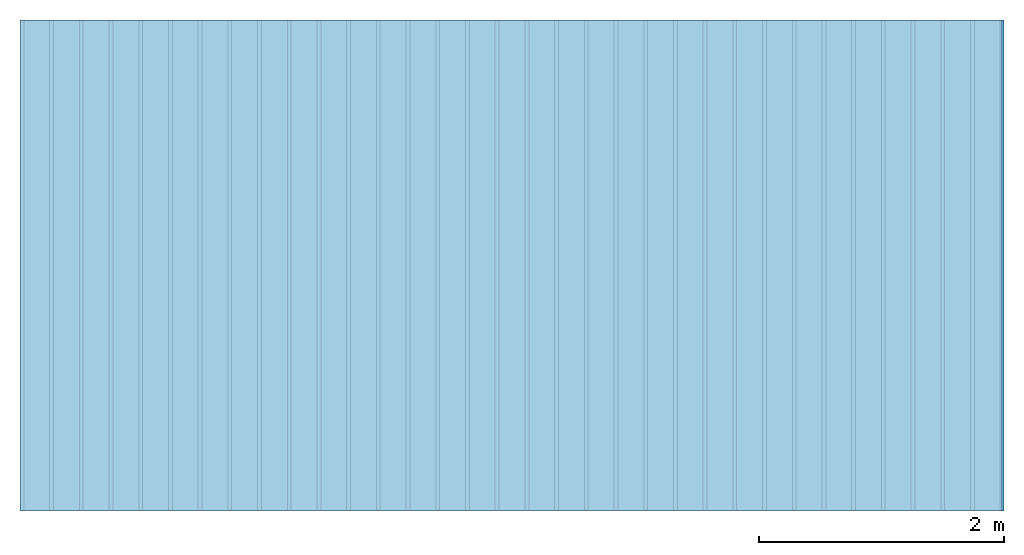
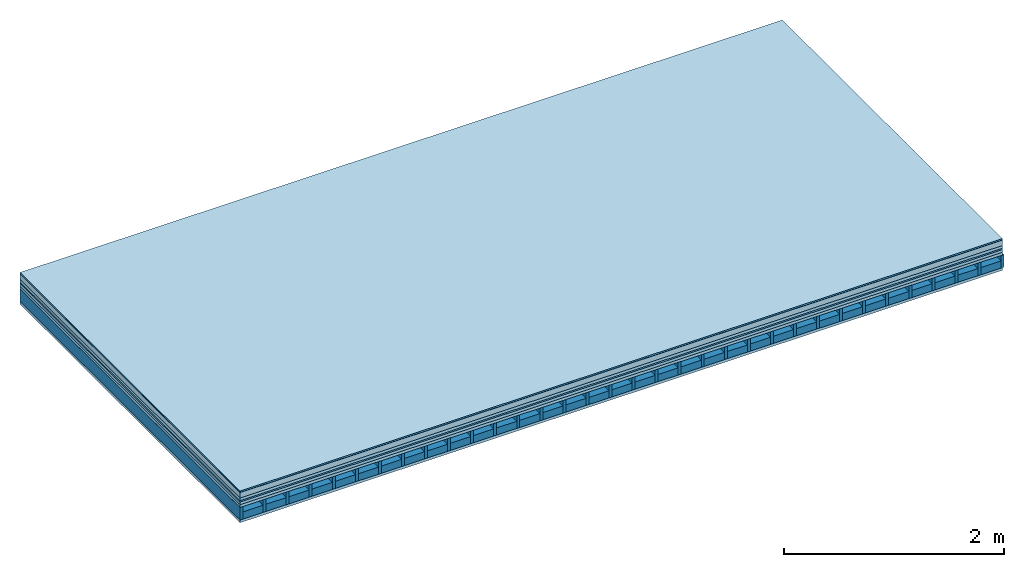
# One storey: 8 plates, 2 members, 1 element without a shape of its own.
"""IFC4 building model written with IfcOpenShell, lengths in metres."""

from ifc_helpers import new_model, si_unit, derived_unit, direction, frame, frame_2d, origin, origin_with_axes, place, context, project, spatial, rectangle, extrude, material, layer, layer_set, type_object, element, aggregate, save


model = new_model("IFC4")

# Units and contexts
plan_context = context("Plan", 3, precision=1e-05, world=origin(), true_north=direction((0.0, 1.0)))
model_context = context("Model", 3, precision=1e-05, world=origin(), true_north=direction((0.0, 1.0)))
ifc_project = project(units=[si_unit("LENGTHUNIT", "METRE"), derived_unit("SOUNDPRESSUREUNIT", [(si_unit("PRESSUREUNIT", "PASCAL", prefix="MICRO"), 0)]), si_unit("ENERGYUNIT", "JOULE", prefix="MEGA"), si_unit("MASSUNIT", "GRAM", prefix="KILO"), derived_unit("THERMALTRANSMITTANCEUNIT", [(si_unit("POWERUNIT", "WATT"), 1), (si_unit("AREAUNIT", "SQUARE_METRE"), -1), (si_unit("THERMODYNAMICTEMPERATUREUNIT", "KELVIN"), -1)]), derived_unit("AREADENSITYUNIT", [(si_unit("MASSUNIT", "GRAM", prefix="KILO"), 1), (si_unit("AREAUNIT", "SQUARE_METRE"), -1)]), derived_unit("USERDEFINED", [(si_unit("ENERGYUNIT", "JOULE", prefix="MEGA"), 1), (si_unit("AREAUNIT", "SQUARE_METRE"), -1)])], contexts=[plan_context, model_context])

# Site, building, storey
site = spatial("IfcSite", under=ifc_project)
building_placement = place(None, origin())
building = spatial("IfcBuilding", under=site, at=building_placement)
storey_placement = place(building_placement, origin())
storey = spatial("IfcBuildingStorey", under=building, at=storey_placement)

# Slab, members, plates
ifc_material_1 = material(Name="Solid wood parquet", Category="11.018")
ifc_layer_1 = layer(ifc_material_1, 0.015, Name="Flooring")
ifc_material_2 = material(Category="09.007")
ifc_layer_2 = layer(ifc_material_2, 0.002, Name="layer")
ifc_material_3 = material(Name="Cement screed", Category="04.006")
ifc_layer_3 = layer(ifc_material_3, 0.06, Name="On-material")
ifc_material_4 = material()
ifc_layer_4 = layer(ifc_material_4, 0.03, Name="Impact sound insulation")
ifc_material_5 = material(Name="OSB panel", Category="07.013")
ifc_layer_5 = layer(ifc_material_5, 0.015, Name="Additional insulation")
ifc_material_6 = material(Name="with broken")
ifc_layer_6 = layer(ifc_material_6, 0.03, Name="on Supporting structure")
ifc_material_7 = material(Name="Element above")
ifc_layer_7 = layer(ifc_material_7, 0.0305, Name="Sub-floor")
ifc_material_8 = material(Name="Rigid")
ifc_layer_8 = layer(ifc_material_8, 0.0, Name="Bond")
ifc_layer_9 = layer(None, 0.139, Name="Supporting structure")
ifc_material_9 = material(Name="Rigid, of the art")
ifc_layer_10 = layer(ifc_material_9, 0.0, Name="Bond")
ifc_material_10 = material(Name="Element below")
ifc_layer_11 = layer(ifc_material_10, 0.0305, Name="Lower layer 1")
ifc_layer_set = layer_set([ifc_layer_1, ifc_layer_2, ifc_layer_3, ifc_layer_4, ifc_layer_5, ifc_layer_6, ifc_layer_7, ifc_layer_8, ifc_layer_9, ifc_layer_10, ifc_layer_11])
slab_type = type_object("IfcSlabType", Name="A2280", PredefinedType="NOTDEFINED", material=ifc_layer_set)
slab_placement = place(None, frame((0.0, 0.0, 0.0), z_axis=(0.0, 0.0, -1.0), x_axis=(1.0, 0.0, 0.0)))
slab = element("IfcSlab", 1, at=slab_placement, inside=storey, type_object=slab_type, material=ifc_layer_set, Name="Slab #1")
ifc_material_11 = material(Name="Floor element EB")
member_1_placement = place(slab_placement, origin())
member_1 = element("IfcMember", 2, at=member_1_placement, material=ifc_material_11, Name="Supporting structure", context=plan_context, shape_type="SweptSolid", body=[
    extrude(rectangle(XDim=0.031, YDim=0.139, at=frame_2d((0.0155, 0.0695), x_axis=(1.0, 0.0))), frame((0.0, 4.0, 0.1825), z_axis=(0.0, -1.0, 0.0), x_axis=(1.0, 0.0, 0.0)), (0.0, 0.0, 1.0), 4.0),
    extrude(rectangle(XDim=0.031, YDim=0.139, at=frame_2d((0.0155, 0.0695), x_axis=(1.0, 0.0))), frame((0.242, 4.0, 0.1825), z_axis=(0.0, -1.0, 0.0), x_axis=(1.0, 0.0, 0.0)), (0.0, 0.0, 1.0), 4.0),
    extrude(rectangle(XDim=0.031, YDim=0.139, at=frame_2d((0.0155, 0.0695), x_axis=(1.0, 0.0))), frame((0.484, 4.0, 0.1825), z_axis=(0.0, -1.0, 0.0), x_axis=(1.0, 0.0, 0.0)), (0.0, 0.0, 1.0), 4.0),
    extrude(rectangle(XDim=0.031, YDim=0.139, at=frame_2d((0.0155, 0.0695), x_axis=(1.0, 0.0))), frame((0.726, 4.0, 0.1825), z_axis=(0.0, -1.0, 0.0), x_axis=(1.0, 0.0, 0.0)), (0.0, 0.0, 1.0), 4.0),
    extrude(rectangle(XDim=0.031, YDim=0.139, at=frame_2d((0.0155, 0.0695), x_axis=(1.0, 0.0))), frame((0.968, 4.0, 0.1825), z_axis=(0.0, -1.0, 0.0), x_axis=(1.0, 0.0, 0.0)), (0.0, 0.0, 1.0), 4.0),
    extrude(rectangle(XDim=0.031, YDim=0.139, at=frame_2d((0.0155, 0.0695), x_axis=(1.0, 0.0))), frame((1.21, 4.0, 0.1825), z_axis=(0.0, -1.0, 0.0), x_axis=(1.0, 0.0, 0.0)), (0.0, 0.0, 1.0), 4.0),
    extrude(rectangle(XDim=0.031, YDim=0.139, at=frame_2d((0.0155, 0.0695), x_axis=(1.0, 0.0))), frame((1.452, 4.0, 0.1825), z_axis=(0.0, -1.0, 0.0), x_axis=(1.0, 0.0, 0.0)), (0.0, 0.0, 1.0), 4.0),
    extrude(rectangle(XDim=0.031, YDim=0.139, at=frame_2d((0.0155, 0.0695), x_axis=(1.0, 0.0))), frame((1.694, 4.0, 0.1825), z_axis=(0.0, -1.0, 0.0), x_axis=(1.0, 0.0, 0.0)), (0.0, 0.0, 1.0), 4.0),
    extrude(rectangle(XDim=0.031, YDim=0.139, at=frame_2d((0.0155, 0.0695), x_axis=(1.0, 0.0))), frame((1.936, 4.0, 0.1825), z_axis=(0.0, -1.0, 0.0), x_axis=(1.0, 0.0, 0.0)), (0.0, 0.0, 1.0), 4.0),
    extrude(rectangle(XDim=0.031, YDim=0.139, at=frame_2d((0.0155, 0.0695), x_axis=(1.0, 0.0))), frame((2.178, 4.0, 0.1825), z_axis=(0.0, -1.0, 0.0), x_axis=(1.0, 0.0, 0.0)), (0.0, 0.0, 1.0), 4.0),
    extrude(rectangle(XDim=0.031, YDim=0.139, at=frame_2d((0.0155, 0.0695), x_axis=(1.0, 0.0))), frame((2.42, 4.0, 0.1825), z_axis=(0.0, -1.0, 0.0), x_axis=(1.0, 0.0, 0.0)), (0.0, 0.0, 1.0), 4.0),
    extrude(rectangle(XDim=0.031, YDim=0.139, at=frame_2d((0.0155, 0.0695), x_axis=(1.0, 0.0))), frame((2.662, 4.0, 0.1825), z_axis=(0.0, -1.0, 0.0), x_axis=(1.0, 0.0, 0.0)), (0.0, 0.0, 1.0), 4.0),
    extrude(rectangle(XDim=0.031, YDim=0.139, at=frame_2d((0.0155, 0.0695), x_axis=(1.0, 0.0))), frame((2.904, 4.0, 0.1825), z_axis=(0.0, -1.0, 0.0), x_axis=(1.0, 0.0, 0.0)), (0.0, 0.0, 1.0), 4.0),
    extrude(rectangle(XDim=0.031, YDim=0.139, at=frame_2d((0.0155, 0.0695), x_axis=(1.0, 0.0))), frame((3.146, 4.0, 0.1825), z_axis=(0.0, -1.0, 0.0), x_axis=(1.0, 0.0, 0.0)), (0.0, 0.0, 1.0), 4.0),
    extrude(rectangle(XDim=0.031, YDim=0.139, at=frame_2d((0.0155, 0.0695), x_axis=(1.0, 0.0))), frame((3.388, 4.0, 0.1825), z_axis=(0.0, -1.0, 0.0), x_axis=(1.0, 0.0, 0.0)), (0.0, 0.0, 1.0), 4.0),
    extrude(rectangle(XDim=0.031, YDim=0.139, at=frame_2d((0.0155, 0.0695), x_axis=(1.0, 0.0))), frame((3.63, 4.0, 0.1825), z_axis=(0.0, -1.0, 0.0), x_axis=(1.0, 0.0, 0.0)), (0.0, 0.0, 1.0), 4.0),
    extrude(rectangle(XDim=0.031, YDim=0.139, at=frame_2d((0.0155, 0.0695), x_axis=(1.0, 0.0))), frame((3.872, 4.0, 0.1825), z_axis=(0.0, -1.0, 0.0), x_axis=(1.0, 0.0, 0.0)), (0.0, 0.0, 1.0), 4.0),
    extrude(rectangle(XDim=0.031, YDim=0.139, at=frame_2d((0.0155, 0.0695), x_axis=(1.0, 0.0))), frame((4.114, 4.0, 0.1825), z_axis=(0.0, -1.0, 0.0), x_axis=(1.0, 0.0, 0.0)), (0.0, 0.0, 1.0), 4.0),
    extrude(rectangle(XDim=0.031, YDim=0.139, at=frame_2d((0.0155, 0.0695), x_axis=(1.0, 0.0))), frame((4.356, 4.0, 0.1825), z_axis=(0.0, -1.0, 0.0), x_axis=(1.0, 0.0, 0.0)), (0.0, 0.0, 1.0), 4.0),
    extrude(rectangle(XDim=0.031, YDim=0.139, at=frame_2d((0.0155, 0.0695), x_axis=(1.0, 0.0))), frame((4.598, 4.0, 0.1825), z_axis=(0.0, -1.0, 0.0), x_axis=(1.0, 0.0, 0.0)), (0.0, 0.0, 1.0), 4.0),
    extrude(rectangle(XDim=0.031, YDim=0.139, at=frame_2d((0.0155, 0.0695), x_axis=(1.0, 0.0))), frame((4.84, 4.0, 0.1825), z_axis=(0.0, -1.0, 0.0), x_axis=(1.0, 0.0, 0.0)), (0.0, 0.0, 1.0), 4.0),
    extrude(rectangle(XDim=0.031, YDim=0.139, at=frame_2d((0.0155, 0.0695), x_axis=(1.0, 0.0))), frame((5.082, 4.0, 0.1825), z_axis=(0.0, -1.0, 0.0), x_axis=(1.0, 0.0, 0.0)), (0.0, 0.0, 1.0), 4.0),
    extrude(rectangle(XDim=0.031, YDim=0.139, at=frame_2d((0.0155, 0.0695), x_axis=(1.0, 0.0))), frame((5.324, 4.0, 0.1825), z_axis=(0.0, -1.0, 0.0), x_axis=(1.0, 0.0, 0.0)), (0.0, 0.0, 1.0), 4.0),
    extrude(rectangle(XDim=0.031, YDim=0.139, at=frame_2d((0.0155, 0.0695), x_axis=(1.0, 0.0))), frame((5.566, 4.0, 0.1825), z_axis=(0.0, -1.0, 0.0), x_axis=(1.0, 0.0, 0.0)), (0.0, 0.0, 1.0), 4.0),
    extrude(rectangle(XDim=0.031, YDim=0.139, at=frame_2d((0.0155, 0.0695), x_axis=(1.0, 0.0))), frame((5.808, 4.0, 0.1825), z_axis=(0.0, -1.0, 0.0), x_axis=(1.0, 0.0, 0.0)), (0.0, 0.0, 1.0), 4.0),
    extrude(rectangle(XDim=0.031, YDim=0.139, at=frame_2d((0.0155, 0.0695), x_axis=(1.0, 0.0))), frame((6.05, 4.0, 0.1825), z_axis=(0.0, -1.0, 0.0), x_axis=(1.0, 0.0, 0.0)), (0.0, 0.0, 1.0), 4.0),
    extrude(rectangle(XDim=0.031, YDim=0.139, at=frame_2d((0.0155, 0.0695), x_axis=(1.0, 0.0))), frame((6.292, 4.0, 0.1825), z_axis=(0.0, -1.0, 0.0), x_axis=(1.0, 0.0, 0.0)), (0.0, 0.0, 1.0), 4.0),
    extrude(rectangle(XDim=0.031, YDim=0.139, at=frame_2d((0.0155, 0.0695), x_axis=(1.0, 0.0))), frame((6.534, 4.0, 0.1825), z_axis=(0.0, -1.0, 0.0), x_axis=(1.0, 0.0, 0.0)), (0.0, 0.0, 1.0), 4.0),
    extrude(rectangle(XDim=0.031, YDim=0.139, at=frame_2d((0.0155, 0.0695), x_axis=(1.0, 0.0))), frame((6.776, 4.0, 0.1825), z_axis=(0.0, -1.0, 0.0), x_axis=(1.0, 0.0, 0.0)), (0.0, 0.0, 1.0), 4.0),
    extrude(rectangle(XDim=0.031, YDim=0.139, at=frame_2d((0.0155, 0.0695), x_axis=(1.0, 0.0))), frame((7.018, 4.0, 0.1825), z_axis=(0.0, -1.0, 0.0), x_axis=(1.0, 0.0, 0.0)), (0.0, 0.0, 1.0), 4.0),
    extrude(rectangle(XDim=0.031, YDim=0.139, at=frame_2d((0.0155, 0.0695), x_axis=(1.0, 0.0))), frame((7.26, 4.0, 0.1825), z_axis=(0.0, -1.0, 0.0), x_axis=(1.0, 0.0, 0.0)), (0.0, 0.0, 1.0), 4.0),
    extrude(rectangle(XDim=0.031, YDim=0.139, at=frame_2d((0.0155, 0.0695), x_axis=(1.0, 0.0))), frame((7.502, 4.0, 0.1825), z_axis=(0.0, -1.0, 0.0), x_axis=(1.0, 0.0, 0.0)), (0.0, 0.0, 1.0), 4.0),
    extrude(rectangle(XDim=0.031, YDim=0.139, at=frame_2d((0.0155, 0.0695), x_axis=(1.0, 0.0))), frame((7.744, 4.0, 0.1825), z_axis=(0.0, -1.0, 0.0), x_axis=(1.0, 0.0, 0.0)), (0.0, 0.0, 1.0), 4.0),
    extrude(rectangle(XDim=0.031, YDim=0.139, at=frame_2d((0.0155, 0.0695), x_axis=(1.0, 0.0))), frame((7.986, 4.0, 0.1825), z_axis=(0.0, -1.0, 0.0), x_axis=(1.0, 0.0, 0.0)), (0.0, 0.0, 1.0), 4.0),
])
ifc_material_12 = material(Name="CCN 2-3mm")
member_2_placement = place(slab_placement, origin())
member_2 = element("IfcMember", 3, at=member_2_placement, material=ifc_material_12, Name="in supporting structure", context=plan_context, shape_type="SweptSolid", body=[
    extrude(rectangle(XDim=0.211, YDim=0.0793, at=frame_2d((0.1055, 0.03965), x_axis=(1.0, 0.0))), frame((0.031, 4.0, 0.2422), z_axis=(0.0, -1.0, 0.0), x_axis=(1.0, 0.0, 0.0)), (0.0, 0.0, 1.0), 4.0),
    extrude(rectangle(XDim=0.211, YDim=0.0793, at=frame_2d((0.1055, 0.03965), x_axis=(1.0, 0.0))), frame((0.273, 4.0, 0.2422), z_axis=(0.0, -1.0, 0.0), x_axis=(1.0, 0.0, 0.0)), (0.0, 0.0, 1.0), 4.0),
    extrude(rectangle(XDim=0.211, YDim=0.0793, at=frame_2d((0.1055, 0.03965), x_axis=(1.0, 0.0))), frame((0.515, 4.0, 0.2422), z_axis=(0.0, -1.0, 0.0), x_axis=(1.0, 0.0, 0.0)), (0.0, 0.0, 1.0), 4.0),
    extrude(rectangle(XDim=0.211, YDim=0.0793, at=frame_2d((0.1055, 0.03965), x_axis=(1.0, 0.0))), frame((0.757, 4.0, 0.2422), z_axis=(0.0, -1.0, 0.0), x_axis=(1.0, 0.0, 0.0)), (0.0, 0.0, 1.0), 4.0),
    extrude(rectangle(XDim=0.211, YDim=0.0793, at=frame_2d((0.1055, 0.03965), x_axis=(1.0, 0.0))), frame((0.999, 4.0, 0.2422), z_axis=(0.0, -1.0, 0.0), x_axis=(1.0, 0.0, 0.0)), (0.0, 0.0, 1.0), 4.0),
    extrude(rectangle(XDim=0.211, YDim=0.0793, at=frame_2d((0.1055, 0.03965), x_axis=(1.0, 0.0))), frame((1.241, 4.0, 0.2422), z_axis=(0.0, -1.0, 0.0), x_axis=(1.0, 0.0, 0.0)), (0.0, 0.0, 1.0), 4.0),
    extrude(rectangle(XDim=0.211, YDim=0.0793, at=frame_2d((0.1055, 0.03965), x_axis=(1.0, 0.0))), frame((1.483, 4.0, 0.2422), z_axis=(0.0, -1.0, 0.0), x_axis=(1.0, 0.0, 0.0)), (0.0, 0.0, 1.0), 4.0),
    extrude(rectangle(XDim=0.211, YDim=0.0793, at=frame_2d((0.1055, 0.03965), x_axis=(1.0, 0.0))), frame((1.725, 4.0, 0.2422), z_axis=(0.0, -1.0, 0.0), x_axis=(1.0, 0.0, 0.0)), (0.0, 0.0, 1.0), 4.0),
    extrude(rectangle(XDim=0.211, YDim=0.0793, at=frame_2d((0.1055, 0.03965), x_axis=(1.0, 0.0))), frame((1.967, 4.0, 0.2422), z_axis=(0.0, -1.0, 0.0), x_axis=(1.0, 0.0, 0.0)), (0.0, 0.0, 1.0), 4.0),
    extrude(rectangle(XDim=0.211, YDim=0.0793, at=frame_2d((0.1055, 0.03965), x_axis=(1.0, 0.0))), frame((2.209, 4.0, 0.2422), z_axis=(0.0, -1.0, 0.0), x_axis=(1.0, 0.0, 0.0)), (0.0, 0.0, 1.0), 4.0),
    extrude(rectangle(XDim=0.211, YDim=0.0793, at=frame_2d((0.1055, 0.03965), x_axis=(1.0, 0.0))), frame((2.451, 4.0, 0.2422), z_axis=(0.0, -1.0, 0.0), x_axis=(1.0, 0.0, 0.0)), (0.0, 0.0, 1.0), 4.0),
    extrude(rectangle(XDim=0.211, YDim=0.0793, at=frame_2d((0.1055, 0.03965), x_axis=(1.0, 0.0))), frame((2.693, 4.0, 0.2422), z_axis=(0.0, -1.0, 0.0), x_axis=(1.0, 0.0, 0.0)), (0.0, 0.0, 1.0), 4.0),
    extrude(rectangle(XDim=0.211, YDim=0.0793, at=frame_2d((0.1055, 0.03965), x_axis=(1.0, 0.0))), frame((2.935, 4.0, 0.2422), z_axis=(0.0, -1.0, 0.0), x_axis=(1.0, 0.0, 0.0)), (0.0, 0.0, 1.0), 4.0),
    extrude(rectangle(XDim=0.211, YDim=0.0793, at=frame_2d((0.1055, 0.03965), x_axis=(1.0, 0.0))), frame((3.177, 4.0, 0.2422), z_axis=(0.0, -1.0, 0.0), x_axis=(1.0, 0.0, 0.0)), (0.0, 0.0, 1.0), 4.0),
    extrude(rectangle(XDim=0.211, YDim=0.0793, at=frame_2d((0.1055, 0.03965), x_axis=(1.0, 0.0))), frame((3.419, 4.0, 0.2422), z_axis=(0.0, -1.0, 0.0), x_axis=(1.0, 0.0, 0.0)), (0.0, 0.0, 1.0), 4.0),
    extrude(rectangle(XDim=0.211, YDim=0.0793, at=frame_2d((0.1055, 0.03965), x_axis=(1.0, 0.0))), frame((3.661, 4.0, 0.2422), z_axis=(0.0, -1.0, 0.0), x_axis=(1.0, 0.0, 0.0)), (0.0, 0.0, 1.0), 4.0),
    extrude(rectangle(XDim=0.211, YDim=0.0793, at=frame_2d((0.1055, 0.03965), x_axis=(1.0, 0.0))), frame((3.903, 4.0, 0.2422), z_axis=(0.0, -1.0, 0.0), x_axis=(1.0, 0.0, 0.0)), (0.0, 0.0, 1.0), 4.0),
    extrude(rectangle(XDim=0.211, YDim=0.0793, at=frame_2d((0.1055, 0.03965), x_axis=(1.0, 0.0))), frame((4.145, 4.0, 0.2422), z_axis=(0.0, -1.0, 0.0), x_axis=(1.0, 0.0, 0.0)), (0.0, 0.0, 1.0), 4.0),
    extrude(rectangle(XDim=0.211, YDim=0.0793, at=frame_2d((0.1055, 0.03965), x_axis=(1.0, 0.0))), frame((4.387, 4.0, 0.2422), z_axis=(0.0, -1.0, 0.0), x_axis=(1.0, 0.0, 0.0)), (0.0, 0.0, 1.0), 4.0),
    extrude(rectangle(XDim=0.211, YDim=0.0793, at=frame_2d((0.1055, 0.03965), x_axis=(1.0, 0.0))), frame((4.629, 4.0, 0.2422), z_axis=(0.0, -1.0, 0.0), x_axis=(1.0, 0.0, 0.0)), (0.0, 0.0, 1.0), 4.0),
    extrude(rectangle(XDim=0.211, YDim=0.0793, at=frame_2d((0.1055, 0.03965), x_axis=(1.0, 0.0))), frame((4.871, 4.0, 0.2422), z_axis=(0.0, -1.0, 0.0), x_axis=(1.0, 0.0, 0.0)), (0.0, 0.0, 1.0), 4.0),
    extrude(rectangle(XDim=0.211, YDim=0.0793, at=frame_2d((0.1055, 0.03965), x_axis=(1.0, 0.0))), frame((5.113, 4.0, 0.2422), z_axis=(0.0, -1.0, 0.0), x_axis=(1.0, 0.0, 0.0)), (0.0, 0.0, 1.0), 4.0),
    extrude(rectangle(XDim=0.211, YDim=0.0793, at=frame_2d((0.1055, 0.03965), x_axis=(1.0, 0.0))), frame((5.355, 4.0, 0.2422), z_axis=(0.0, -1.0, 0.0), x_axis=(1.0, 0.0, 0.0)), (0.0, 0.0, 1.0), 4.0),
    extrude(rectangle(XDim=0.211, YDim=0.0793, at=frame_2d((0.1055, 0.03965), x_axis=(1.0, 0.0))), frame((5.597, 4.0, 0.2422), z_axis=(0.0, -1.0, 0.0), x_axis=(1.0, 0.0, 0.0)), (0.0, 0.0, 1.0), 4.0),
    extrude(rectangle(XDim=0.211, YDim=0.0793, at=frame_2d((0.1055, 0.03965), x_axis=(1.0, 0.0))), frame((5.839, 4.0, 0.2422), z_axis=(0.0, -1.0, 0.0), x_axis=(1.0, 0.0, 0.0)), (0.0, 0.0, 1.0), 4.0),
    extrude(rectangle(XDim=0.211, YDim=0.0793, at=frame_2d((0.1055, 0.03965), x_axis=(1.0, 0.0))), frame((6.081, 4.0, 0.2422), z_axis=(0.0, -1.0, 0.0), x_axis=(1.0, 0.0, 0.0)), (0.0, 0.0, 1.0), 4.0),
    extrude(rectangle(XDim=0.211, YDim=0.0793, at=frame_2d((0.1055, 0.03965), x_axis=(1.0, 0.0))), frame((6.323, 4.0, 0.2422), z_axis=(0.0, -1.0, 0.0), x_axis=(1.0, 0.0, 0.0)), (0.0, 0.0, 1.0), 4.0),
    extrude(rectangle(XDim=0.211, YDim=0.0793, at=frame_2d((0.1055, 0.03965), x_axis=(1.0, 0.0))), frame((6.565, 4.0, 0.2422), z_axis=(0.0, -1.0, 0.0), x_axis=(1.0, 0.0, 0.0)), (0.0, 0.0, 1.0), 4.0),
    extrude(rectangle(XDim=0.211, YDim=0.0793, at=frame_2d((0.1055, 0.03965), x_axis=(1.0, 0.0))), frame((6.807, 4.0, 0.2422), z_axis=(0.0, -1.0, 0.0), x_axis=(1.0, 0.0, 0.0)), (0.0, 0.0, 1.0), 4.0),
    extrude(rectangle(XDim=0.211, YDim=0.0793, at=frame_2d((0.1055, 0.03965), x_axis=(1.0, 0.0))), frame((7.049, 4.0, 0.2422), z_axis=(0.0, -1.0, 0.0), x_axis=(1.0, 0.0, 0.0)), (0.0, 0.0, 1.0), 4.0),
    extrude(rectangle(XDim=0.211, YDim=0.0793, at=frame_2d((0.1055, 0.03965), x_axis=(1.0, 0.0))), frame((7.291, 4.0, 0.2422), z_axis=(0.0, -1.0, 0.0), x_axis=(1.0, 0.0, 0.0)), (0.0, 0.0, 1.0), 4.0),
    extrude(rectangle(XDim=0.211, YDim=0.0793, at=frame_2d((0.1055, 0.03965), x_axis=(1.0, 0.0))), frame((7.533, 4.0, 0.2422), z_axis=(0.0, -1.0, 0.0), x_axis=(1.0, 0.0, 0.0)), (0.0, 0.0, 1.0), 4.0),
    extrude(rectangle(XDim=0.211, YDim=0.0793, at=frame_2d((0.1055, 0.03965), x_axis=(1.0, 0.0))), frame((7.775, 4.0, 0.2422), z_axis=(0.0, -1.0, 0.0), x_axis=(1.0, 0.0, 0.0)), (0.0, 0.0, 1.0), 4.0),
])
plate_1_placement = place(slab_placement, origin())
plate_1 = element("IfcPlate", 4, at=plate_1_placement, material=ifc_material_1, Name="Flooring", context=plan_context, shape_type="SweptSolid", body=[
    extrude(rectangle(XDim=8.0, YDim=4.0, at=frame_2d((4.0, 2.0), x_axis=(1.0, 0.0))), origin_with_axes(), (0.0, 0.0, 1.0), 0.015),
])
plate_2_placement = place(slab_placement, origin())
plate_2 = element("IfcPlate", 5, at=plate_2_placement, material=ifc_material_2, Name="layer", context=plan_context, shape_type="SweptSolid", body=[
    extrude(rectangle(XDim=8.0, YDim=4.0, at=frame_2d((4.0, 2.0), x_axis=(1.0, 0.0))), frame((0.0, 0.0, 0.015), z_axis=(0.0, 0.0, 1.0), x_axis=(1.0, 0.0, 0.0)), (0.0, 0.0, 1.0), 0.002),
])
plate_3_placement = place(slab_placement, origin())
plate_3 = element("IfcPlate", 6, at=plate_3_placement, material=ifc_material_3, Name="On-material", context=plan_context, shape_type="SweptSolid", body=[
    extrude(rectangle(XDim=8.0, YDim=4.0, at=frame_2d((4.0, 2.0), x_axis=(1.0, 0.0))), frame((0.0, 0.0, 0.017), z_axis=(0.0, 0.0, 1.0), x_axis=(1.0, 0.0, 0.0)), (0.0, 0.0, 1.0), 0.06),
])
plate_4_placement = place(slab_placement, origin())
plate_4 = element("IfcPlate", 7, at=plate_4_placement, material=ifc_material_4, Name="Impact sound insulation", context=plan_context, shape_type="SweptSolid", body=[
    extrude(rectangle(XDim=8.0, YDim=4.0, at=frame_2d((4.0, 2.0), x_axis=(1.0, 0.0))), frame((0.0, 0.0, 0.077), z_axis=(0.0, 0.0, 1.0), x_axis=(1.0, 0.0, 0.0)), (0.0, 0.0, 1.0), 0.03),
])
plate_5_placement = place(slab_placement, origin())
plate_5 = element("IfcPlate", 8, at=plate_5_placement, material=ifc_material_5, Name="Additional insulation", context=plan_context, shape_type="SweptSolid", body=[
    extrude(rectangle(XDim=8.0, YDim=4.0, at=frame_2d((4.0, 2.0), x_axis=(1.0, 0.0))), frame((0.0, 0.0, 0.107), z_axis=(0.0, 0.0, 1.0), x_axis=(1.0, 0.0, 0.0)), (0.0, 0.0, 1.0), 0.015),
])
plate_6_placement = place(slab_placement, origin())
plate_6 = element("IfcPlate", 9, at=plate_6_placement, material=ifc_material_6, Name="on Supporting structure", context=plan_context, shape_type="SweptSolid", body=[
    extrude(rectangle(XDim=8.0, YDim=4.0, at=frame_2d((4.0, 2.0), x_axis=(1.0, 0.0))), frame((0.0, 0.0, 0.122), z_axis=(0.0, 0.0, 1.0), x_axis=(1.0, 0.0, 0.0)), (0.0, 0.0, 1.0), 0.03),
])
plate_7_placement = place(slab_placement, origin())
plate_7 = element("IfcPlate", 10, at=plate_7_placement, material=ifc_material_7, Name="Sub-floor", context=plan_context, shape_type="SweptSolid", body=[
    extrude(rectangle(XDim=8.0, YDim=4.0, at=frame_2d((4.0, 2.0), x_axis=(1.0, 0.0))), frame((0.0, 0.0, 0.152), z_axis=(0.0, 0.0, 1.0), x_axis=(1.0, 0.0, 0.0)), (0.0, 0.0, 1.0), 0.0305),
])
plate_8_placement = place(slab_placement, origin())
plate_8 = element("IfcPlate", 11, at=plate_8_placement, material=ifc_material_10, Name="Lower layer 1", context=plan_context, shape_type="SweptSolid", body=[
    extrude(rectangle(XDim=8.0, YDim=4.0, at=frame_2d((4.0, 2.0), x_axis=(1.0, 0.0))), frame((0.0, 0.0, 0.3215), z_axis=(0.0, 0.0, 1.0), x_axis=(1.0, 0.0, 0.0)), (0.0, 0.0, 1.0), 0.0305),
])
aggregate(slab, [plate_1, plate_2, plate_3, plate_4, plate_5, plate_6, plate_7, member_1, member_2, plate_8])

save(model, "model.ifc")
